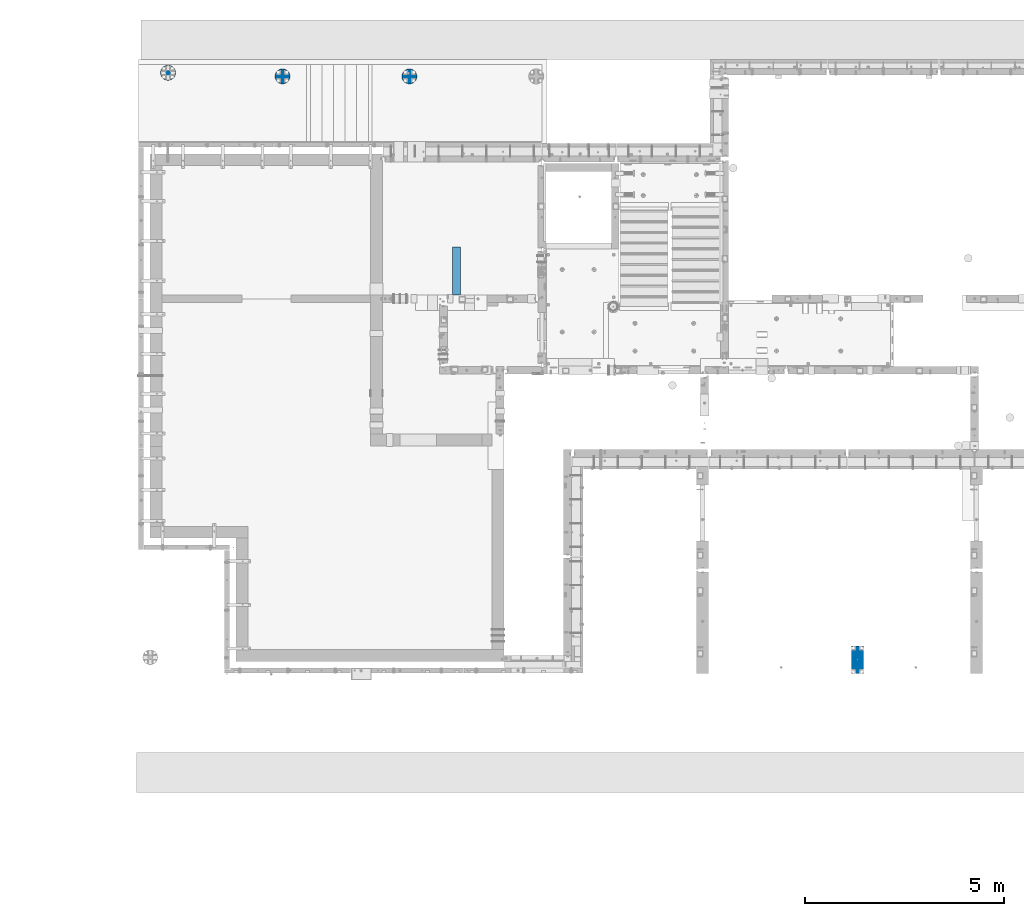
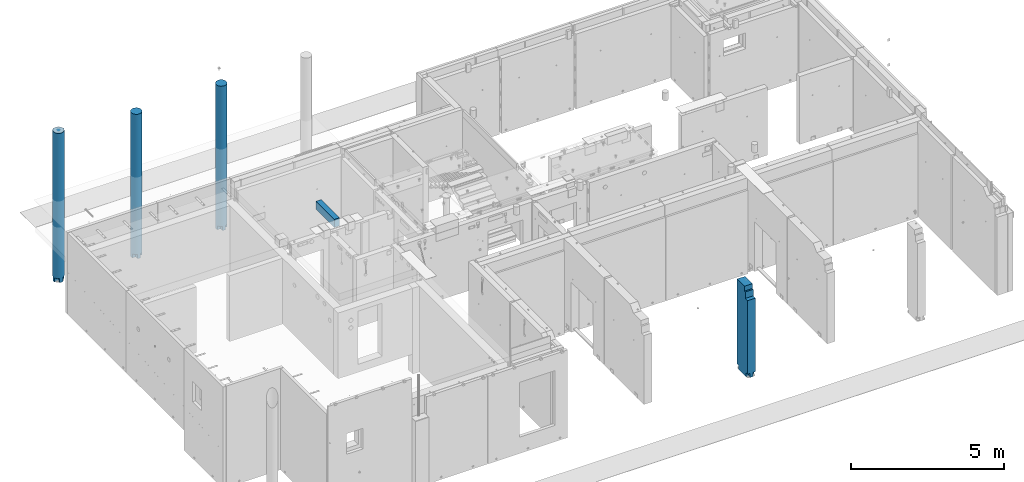
# One storey, part 3 of 264: 5 columns, 5 elements without a shape of their own.
"""IFC2X3 building model written with IfcOpenShell, lengths in millimetres."""

from ifc_helpers import new_model, si_unit, frame, origin_with_axes, place, context, subcontext, project, spatial, faceted_brep, material, type_object, element, aggregate, save


model = new_model("IFC2X3")

# Units and contexts
model_context = context("Model", 3, precision=1e-05, world=origin_with_axes())
body_context = subcontext(model_context, "Body", "Model", "MODEL_VIEW")
ifc_project = project(units=[si_unit("LENGTHUNIT", "METRE", prefix="MILLI"), si_unit("AREAUNIT", "SQUARE_METRE"), si_unit("VOLUMEUNIT", "CUBIC_METRE"), si_unit("MASSUNIT", "GRAM", prefix="KILO"), si_unit("TIMEUNIT", "SECOND"), si_unit("PLANEANGLEUNIT", "RADIAN"), si_unit("SOLIDANGLEUNIT", "STERADIAN"), si_unit("THERMODYNAMICTEMPERATUREUNIT", "DEGREE_CELSIUS"), si_unit("LUMINOUSINTENSITYUNIT", "LUMEN")], contexts=[model_context])

# Site, building, storey
site_placement = place(None, origin_with_axes())
site = spatial("IfcSite", under=ifc_project, at=site_placement, CompositionType="ELEMENT")
building_placement = place(site_placement, origin_with_axes())
building = spatial("IfcBuilding", under=site, at=building_placement, CompositionType="ELEMENT")
storey_placement = place(building_placement, origin_with_axes())
storey = spatial("IfcBuildingStorey", under=building, at=storey_placement, Name="K", CompositionType="ELEMENT", Elevation=0.0)

# Assembly, column
assembly_1_placement = place(storey_placement, origin_with_axes())
assembly_1 = element("IfcElementAssembly", 1, at=assembly_1_placement, inside=storey, AssemblyPlace="NOTDEFINED", PredefinedType="REINFORCEMENT_UNIT")
ifc_material_1 = material(Name="CONCRETE/C35/45")
column_type_1 = type_object("IfcColumnType", Name="D380", PredefinedType="NOTDEFINED")
column_1_placement = place(assembly_1_placement, frame((14374.9987952044, 22579.984888838, 78490.0), z_axis=(0.0, -1.0, 0.0), x_axis=(0.0, 0.0, 1.0)))
column_1 = element("IfcColumn", 2, at=column_1_placement, type_object=column_type_1, material=ifc_material_1, ObjectType="D380", context=body_context, shape_type="Brep", body=[
    faceted_brep([(0.000343322768458165, -58.9912653237152, 59.0010429997965), (165.000343322783, -58.9912653237152, 59.0010429997965), (165.000343322783, -58.9912653237152, 179.698598994491), (0.00034332278301008, -58.9912653237152, 179.698598994488), (165.000343322783, -179.695632968873, 59.0010429997965), (0.00034332278301008, -179.695632968873, 59.0010429997965), (165.000343322783, -175.537111177146, 72.7098521493681), (165.000343322783, -157.979226337484, 105.558344273726), (165.000343322783, -134.350288425445, 134.350288425445), (165.000343322783, -105.558344273726, 157.979226337484), (165.000343322783, -72.7098521493681, 175.537111177146), (0.00034332278301008, -179.699329936011, -58.9888557324375), (0.000343322768458165, -58.9912653237152, -58.9888557324375), (165.000343322783, -58.9912653237152, -58.9888557324375), (165.000343322783, -179.699329936011, -58.9888557324375), (165.000343322783, -58.9912653237152, -179.698598994488), (0.00034332278301008, -58.9912653237152, -179.698598994488), (0.00034332278301008, 58.9986334085152, -179.6963639104), (0.000343322768458165, 58.9986334085152, -58.9888557324375), (165.000343322783, 58.9986334085152, -58.9888557324375), (165.000343322783, 58.9986334085152, -179.696363910396), (0.00034332278301008, 179.699329936011, -58.9888557324375), (165.000343322783, 179.699329936011, -58.9888557324375), (0.00034332278301008, 0.0, 190.0), (0.00034332278301008, -37.0671611830658, 186.349203276615), (5750.0, -37.0671611830658, 186.349203276615), (5750.0, 0.0, 190.0), (0.00034332278301008, 37.0671611830658, 186.349203276615), (5750.0, 37.0671611830658, 186.349203276615), (5750.0, 157.979226337484, 105.558344273726), (5750.0, 175.537111177146, 72.7098521493681), (165.000343322783, 175.537111177146, 72.7098521493681), (165.000343322783, 157.979226337484, 105.558344273726), (5750.0, 134.350288425445, 134.350288425445), (165.000343322783, 134.350288425445, 134.350288425445), (5750.0, 105.558344273726, 157.979226337484), (165.000343322783, 105.558344273726, 157.979226337484), (5750.0, 72.7098521493681, 175.537111177146), (165.000343322783, 72.7098521493681, 175.537111177146), (165.000343322783, 58.9986334085152, 179.696363910396), (0.00034332278301008, 58.9986334085152, 179.6963639104), (0.000343322768458165, 58.9986334085152, 59.0010429997965), (165.000343322783, 58.9986334085152, 59.0010429997965), (165.000343322783, 179.695632968873, 59.0010429997965), (0.00034332278301008, 179.695632968873, 59.0010429997965), (5750.0, 186.349203276615, 37.0671611830658), (0.00034332278301008, 186.349203276615, 37.0671611830658), (0.00034332278301008, 190.0, 0.0), (5750.0, 190.0, 0.0), (0.00034332278301008, 186.349203276615, -37.0671611830658), (5750.0, 186.349203276615, -37.0671611830658), (5750.0, 175.537111177146, -72.7098521493681), (165.000343322783, 175.537111177146, -72.7098521493681), (5750.0, 157.979226337484, -105.558344273726), (165.000343322783, 157.979226337484, -105.558344273726), (5750.0, 134.350288425445, -134.350288425445), (165.000343322783, 134.350288425445, -134.350288425445), (5750.0, 105.558344273726, -157.979226337484), (165.000343322783, 105.558344273726, -157.979226337484), (5750.0, 72.7098521493681, -175.537111177146), (165.000343322783, 72.7098521493681, -175.537111177146), (5750.0, 37.0671611830658, -186.349203276615), (0.00034332278301008, 37.0671611830658, -186.349203276615), (0.00034332278301008, 0.0, -190.0), (5750.0, 0.0, -190.0), (0.00034332278301008, -37.0671611830658, -186.349203276615), (5750.0, -37.0671611830658, -186.349203276615), (5750.0, -72.7098521493681, -175.537111177146), (165.000343322783, -72.7098521493681, -175.537111177146), (5750.0, -105.558344273726, -157.979226337484), (165.000343322783, -105.558344273726, -157.979226337484), (5750.0, -134.350288425445, -134.350288425445), (165.000343322783, -134.350288425445, -134.350288425445), (5750.0, -157.979226337484, -105.558344273726), (165.000343322783, -157.979226337484, -105.558344273726), (5750.0, -175.537111177146, -72.7098521493681), (165.000343322783, -175.537111177146, -72.7098521493681), (5750.0, -186.349203276615, -37.0671611830658), (0.00034332278301008, -186.349203276615, -37.0671611830658), (0.00034332278301008, -190.0, 0.0), (5750.0, -190.0, 0.0), (5750.0, -72.7098521493681, 175.537111177146), (5750.0, -105.558344273726, 157.979226337484), (5750.0, -134.350288425445, 134.350288425445), (5750.0, -157.979226337484, 105.558344273726), (5750.0, -175.537111177146, 72.7098521493681), (5750.0, -186.349203276615, 37.0671611830658), (0.00034332278301008, -186.349203276615, 37.0671611830658)], [[[0, 1, 2, 3]], [[4, 1, 0, 5]], [[6, 7, 8, 9, 10, 2, 1, 4]], [[11, 12, 13, 14]], [[15, 13, 12, 16]], [[17, 18, 19, 20]], [[21, 22, 19, 18]], [[23, 24, 25, 26]], [[27, 23, 26, 28]], [[29, 30, 31, 32]], [[33, 29, 32, 34]], [[35, 33, 34, 36]], [[37, 35, 36, 38]], [[27, 28, 37, 38, 39, 40]], [[41, 42, 43, 44]], [[40, 39, 42, 41]], [[38, 36, 34, 32, 31, 43, 42, 39]], [[30, 45, 46, 44, 43, 31]], [[47, 46, 45, 48]], [[49, 47, 48, 50]], [[21, 49, 50, 51, 52, 22]], [[51, 53, 54, 52]], [[53, 55, 56, 54]], [[55, 57, 58, 56]], [[57, 59, 60, 58]], [[20, 19, 22, 52, 54, 56, 58, 60]], [[59, 61, 62, 17, 20, 60]], [[63, 62, 61, 64]], [[65, 63, 64, 66]], [[16, 65, 66, 67, 68, 15]], [[67, 69, 70, 68]], [[69, 71, 72, 70]], [[71, 73, 74, 72]], [[73, 75, 76, 74]], [[14, 13, 15, 68, 70, 72, 74, 76]], [[75, 77, 78, 11, 14, 76]], [[79, 78, 77, 80]], [[75, 73, 71, 69, 67, 66, 64, 61, 59, 57, 55, 53, 51, 50, 48, 45, 30, 29, 33, 35, 37, 28, 26, 25, 81, 82, 83, 84, 85, 86, 80, 77]], [[87, 79, 80, 86]], [[3, 24, 23, 27, 40, 41, 44, 46, 47, 49, 21, 18, 17, 62, 63, 65, 16, 12, 11, 78, 79, 87, 5, 0]], [[81, 25, 24, 3, 2, 10]], [[82, 81, 10, 9]], [[83, 82, 9, 8]], [[84, 83, 8, 7]], [[85, 84, 7, 6]], [[87, 86, 85, 6, 4, 5]]]),
])
aggregate(assembly_1, [column_1])

assembly_2_placement = place(storey_placement, origin_with_axes())
assembly_2 = element("IfcElementAssembly", 3, at=assembly_2_placement, inside=storey, AssemblyPlace="NOTDEFINED", PredefinedType="REINFORCEMENT_UNIT")
column_2_placement = place(assembly_2_placement, frame((11179.9987952044, 22579.984888838, 78490.0), z_axis=(0.0, -1.0, 0.0), x_axis=(0.0, 0.0, 1.0)))
column_2 = element("IfcColumn", 4, at=column_2_placement, type_object=column_type_1, material=ifc_material_1, ObjectType="D380", context=body_context, shape_type="Brep", body=[
    faceted_brep([(0.000343322768458165, -58.9912653237152, 59.0010429997965), (165.000343322783, -58.9912653237152, 59.0010429997965), (165.000343322783, -58.9912653237152, 179.698598994491), (0.00034332278301008, -58.9912653237152, 179.698598994488), (165.000343322783, -179.695632968873, 59.0010429997965), (0.00034332278301008, -179.695632968873, 59.0010429997965), (165.000343322783, -175.537111177146, 72.7098521493681), (165.000343322783, -157.979226337484, 105.558344273726), (165.000343322783, -134.350288425445, 134.350288425445), (165.000343322783, -105.558344273726, 157.979226337484), (165.000343322783, -72.7098521493681, 175.537111177146), (0.00034332278301008, -179.699329936011, -58.9888557324375), (0.000343322768458165, -58.9912653237152, -58.9888557324375), (165.000343322783, -58.9912653237152, -58.9888557324375), (165.000343322783, -179.699329936011, -58.9888557324375), (165.000343322783, -58.9912653237152, -179.698598994488), (0.00034332278301008, -58.9912653237152, -179.698598994488), (0.00034332278301008, 58.9986334085152, -179.6963639104), (0.000343322768458165, 58.9986334085152, -58.9888557324375), (165.000343322783, 58.9986334085152, -58.9888557324375), (165.000343322783, 58.9986334085152, -179.696363910396), (0.00034332278301008, 179.699329936011, -58.9888557324375), (165.000343322783, 179.699329936011, -58.9888557324375), (0.00034332278301008, 0.0, 190.0), (0.00034332278301008, -37.0671611830658, 186.349203276615), (5750.0, -37.0671611830658, 186.349203276615), (5750.0, 0.0, 190.0), (0.00034332278301008, 37.0671611830658, 186.349203276615), (5750.0, 37.0671611830658, 186.349203276615), (5750.0, 157.979226337484, 105.558344273726), (5750.0, 175.537111177146, 72.7098521493681), (165.000343322783, 175.537111177146, 72.7098521493681), (165.000343322783, 157.979226337484, 105.558344273726), (5750.0, 134.350288425445, 134.350288425445), (165.000343322783, 134.350288425445, 134.350288425445), (5750.0, 105.558344273726, 157.979226337484), (165.000343322783, 105.558344273726, 157.979226337484), (5750.0, 72.7098521493681, 175.537111177146), (165.000343322783, 72.7098521493681, 175.537111177146), (165.000343322783, 58.9986334085152, 179.696363910396), (0.00034332278301008, 58.9986334085152, 179.6963639104), (0.000343322768458165, 58.9986334085152, 59.0010429997965), (165.000343322783, 58.9986334085152, 59.0010429997965), (165.000343322783, 179.695632968873, 59.0010429997965), (0.00034332278301008, 179.695632968873, 59.0010429997965), (5750.0, 186.349203276615, 37.0671611830658), (0.00034332278301008, 186.349203276615, 37.0671611830658), (0.00034332278301008, 190.0, 0.0), (5750.0, 190.0, 0.0), (0.00034332278301008, 186.349203276615, -37.0671611830658), (5750.0, 186.349203276615, -37.0671611830658), (5750.0, 175.537111177146, -72.7098521493681), (165.000343322783, 175.537111177146, -72.7098521493681), (5750.0, 157.979226337484, -105.558344273726), (165.000343322783, 157.979226337484, -105.558344273726), (5750.0, 134.350288425445, -134.350288425445), (165.000343322783, 134.350288425445, -134.350288425445), (5750.0, 105.558344273726, -157.979226337484), (165.000343322783, 105.558344273726, -157.979226337484), (5750.0, 72.7098521493681, -175.537111177146), (165.000343322783, 72.7098521493681, -175.537111177146), (5750.0, 37.0671611830658, -186.349203276615), (0.00034332278301008, 37.0671611830658, -186.349203276615), (0.00034332278301008, 0.0, -190.0), (5750.0, 0.0, -190.0), (0.00034332278301008, -37.0671611830658, -186.349203276615), (5750.0, -37.0671611830658, -186.349203276615), (5750.0, -72.7098521493681, -175.537111177146), (165.000343322783, -72.7098521493681, -175.537111177146), (5750.0, -105.558344273726, -157.979226337484), (165.000343322783, -105.558344273726, -157.979226337484), (5750.0, -134.350288425445, -134.350288425445), (165.000343322783, -134.350288425445, -134.350288425445), (5750.0, -157.979226337484, -105.558344273726), (165.000343322783, -157.979226337484, -105.558344273726), (5750.0, -175.537111177146, -72.7098521493681), (165.000343322783, -175.537111177146, -72.7098521493681), (5750.0, -186.349203276615, -37.0671611830658), (0.00034332278301008, -186.349203276615, -37.0671611830658), (0.00034332278301008, -190.0, 0.0), (5750.0, -190.0, 0.0), (5750.0, -72.7098521493681, 175.537111177146), (5750.0, -105.558344273726, 157.979226337484), (5750.0, -134.350288425445, 134.350288425445), (5750.0, -157.979226337484, 105.558344273726), (5750.0, -175.537111177146, 72.7098521493681), (5750.0, -186.349203276615, 37.0671611830658), (0.00034332278301008, -186.349203276615, 37.0671611830658)], [[[0, 1, 2, 3]], [[4, 1, 0, 5]], [[6, 7, 8, 9, 10, 2, 1, 4]], [[11, 12, 13, 14]], [[15, 13, 12, 16]], [[17, 18, 19, 20]], [[21, 22, 19, 18]], [[23, 24, 25, 26]], [[27, 23, 26, 28]], [[29, 30, 31, 32]], [[33, 29, 32, 34]], [[35, 33, 34, 36]], [[37, 35, 36, 38]], [[27, 28, 37, 38, 39, 40]], [[41, 42, 43, 44]], [[40, 39, 42, 41]], [[38, 36, 34, 32, 31, 43, 42, 39]], [[30, 45, 46, 44, 43, 31]], [[47, 46, 45, 48]], [[49, 47, 48, 50]], [[21, 49, 50, 51, 52, 22]], [[51, 53, 54, 52]], [[53, 55, 56, 54]], [[55, 57, 58, 56]], [[57, 59, 60, 58]], [[20, 19, 22, 52, 54, 56, 58, 60]], [[59, 61, 62, 17, 20, 60]], [[63, 62, 61, 64]], [[65, 63, 64, 66]], [[16, 65, 66, 67, 68, 15]], [[67, 69, 70, 68]], [[69, 71, 72, 70]], [[71, 73, 74, 72]], [[73, 75, 76, 74]], [[14, 13, 15, 68, 70, 72, 74, 76]], [[75, 77, 78, 11, 14, 76]], [[79, 78, 77, 80]], [[75, 73, 71, 69, 67, 66, 64, 61, 59, 57, 55, 53, 51, 50, 48, 45, 30, 29, 33, 35, 37, 28, 26, 25, 81, 82, 83, 84, 85, 86, 80, 77]], [[87, 79, 80, 86]], [[3, 24, 23, 27, 40, 41, 44, 46, 47, 49, 21, 18, 17, 62, 63, 65, 16, 12, 11, 78, 79, 87, 5, 0]], [[81, 25, 24, 3, 2, 10]], [[82, 81, 10, 9]], [[83, 82, 9, 8]], [[84, 83, 8, 7]], [[85, 84, 7, 6]], [[87, 86, 85, 6, 4, 5]]]),
])
aggregate(assembly_2, [column_2])

assembly_3_placement = place(storey_placement, origin_with_axes())
assembly_3 = element("IfcElementAssembly", 5, at=assembly_3_placement, inside=storey, AssemblyPlace="NOTDEFINED", PredefinedType="REINFORCEMENT_UNIT")
column_3_placement = place(assembly_3_placement, frame((8299.99879520436, 22669.984888838, 78490.0), z_axis=(0.0, -1.0, 0.0), x_axis=(0.0, 0.0, 1.0)))
column_3 = element("IfcColumn", 6, at=column_3_placement, type_object=column_type_1, material=ifc_material_1, ObjectType="D380", context=body_context, shape_type="Brep", body=[
    faceted_brep([(0.000343322768458165, -58.9912653237152, 59.0010429997965), (165.000343322783, -58.9912653237152, 59.0010429997965), (165.000343322783, -58.9912653237152, 179.698598994491), (0.00034332278301008, -58.9912653237152, 179.698598994488), (165.000343322783, -179.695632968873, 59.0010429997965), (0.00034332278301008, -179.695632968873, 59.0010429997965), (165.000343322783, -175.537111177146, 72.7098521493681), (165.000343322783, -157.979226337484, 105.558344273726), (165.000343322783, -134.350288425445, 134.350288425445), (165.000343322783, -105.558344273726, 157.979226337484), (165.000343322783, -72.7098521493681, 175.537111177146), (0.00034332278301008, -179.699329936011, -58.9888557324375), (0.000343322768458165, -58.9912653237152, -58.9888557324375), (165.000343322783, -58.9912653237152, -58.9888557324375), (165.000343322783, -179.699329936011, -58.9888557324375), (165.000343322783, -58.9912653237152, -179.698598994488), (0.00034332278301008, -58.9912653237152, -179.698598994488), (0.00034332278301008, 58.9986334085152, -179.6963639104), (0.000343322768458165, 58.9986334085152, -58.9888557324375), (165.000343322783, 58.9986334085152, -58.9888557324375), (165.000343322783, 58.9986334085152, -179.696363910396), (0.00034332278301008, 179.699329936011, -58.9888557324375), (165.000343322783, 179.699329936011, -58.9888557324375), (0.00034332278301008, 0.0, 190.0), (0.00034332278301008, -37.0671611830658, 186.349203276615), (5945.0, -37.0671611830639, 186.349203276615), (5945.0, 0.0, 190.0), (0.00034332278301008, 37.0671611830658, 186.349203276615), (5945.0, 37.0671611830639, 186.349203276615), (5945.0, 157.979226337484, 105.558344273726), (5945.0, 175.537111177145, 72.7098521493681), (165.000343322783, 175.537111177146, 72.7098521493681), (165.000343322783, 157.979226337484, 105.558344273726), (5945.0, 134.350288425444, 134.350288425445), (165.000343322783, 134.350288425445, 134.350288425445), (5945.0, 105.558344273724, 157.979226337484), (165.000343322783, 105.558344273726, 157.979226337484), (5945.0, 72.7098521493663, 175.537111177146), (165.000343322783, 72.7098521493681, 175.537111177146), (165.000343322783, 58.9986334085152, 179.696363910396), (0.00034332278301008, 58.9986334085152, 179.6963639104), (0.000343322768458165, 58.9986334085152, 59.0010429997965), (165.000343322783, 58.9986334085152, 59.0010429997965), (165.000343322783, 179.695632968873, 59.0010429997965), (0.00034332278301008, 179.695632968873, 59.0010429997965), (5945.0, 186.349203276613, 37.0671611830658), (0.00034332278301008, 186.349203276615, 37.0671611830658), (0.00034332278301008, 190.0, 0.0), (5945.0, 190.0, 0.0), (0.00034332278301008, 186.349203276615, -37.0671611830658), (5945.0, 186.349203276613, -37.0671611830658), (5945.0, 175.537111177145, -72.7098521493681), (165.000343322783, 175.537111177146, -72.7098521493681), (5945.0, 157.979226337484, -105.558344273726), (165.000343322783, 157.979226337484, -105.558344273726), (5945.0, 134.350288425444, -134.350288425445), (165.000343322783, 134.350288425445, -134.350288425445), (5945.0, 105.558344273724, -157.979226337484), (165.000343322783, 105.558344273726, -157.979226337484), (5945.0, 72.7098521493663, -175.537111177146), (165.000343322783, 72.7098521493681, -175.537111177146), (5945.0, 37.0671611830639, -186.349203276615), (0.00034332278301008, 37.0671611830658, -186.349203276615), (0.00034332278301008, 0.0, -190.0), (5945.0, 0.0, -190.0), (0.00034332278301008, -37.0671611830658, -186.349203276615), (5945.0, -37.0671611830639, -186.349203276615), (5945.0, -72.7098521493663, -175.537111177146), (165.000343322783, -72.7098521493681, -175.537111177146), (5945.0, -105.558344273724, -157.979226337484), (165.000343322783, -105.558344273726, -157.979226337484), (5945.0, -134.350288425445, -134.350288425445), (165.000343322783, -134.350288425445, -134.350288425445), (5945.0, -157.979226337484, -105.558344273726), (165.000343322783, -157.979226337484, -105.558344273726), (5945.0, -175.537111177144, -72.7098521493681), (165.000343322783, -175.537111177146, -72.7098521493681), (5945.0, -186.349203276613, -37.0671611830658), (0.00034332278301008, -186.349203276615, -37.0671611830658), (0.00034332278301008, -190.0, 0.0), (5945.0, -190.0, 0.0), (5945.0, -72.7098521493663, 175.537111177146), (5945.0, -105.558344273724, 157.979226337484), (5945.0, -134.350288425445, 134.350288425445), (5945.0, -157.979226337484, 105.558344273726), (5945.0, -175.537111177144, 72.7098521493681), (5945.0, -186.349203276613, 37.0671611830658), (0.00034332278301008, -186.349203276615, 37.0671611830658)], [[[0, 1, 2, 3]], [[4, 1, 0, 5]], [[6, 7, 8, 9, 10, 2, 1, 4]], [[11, 12, 13, 14]], [[15, 13, 12, 16]], [[17, 18, 19, 20]], [[21, 22, 19, 18]], [[23, 24, 25, 26]], [[27, 23, 26, 28]], [[29, 30, 31, 32]], [[33, 29, 32, 34]], [[35, 33, 34, 36]], [[37, 35, 36, 38]], [[27, 28, 37, 38, 39, 40]], [[41, 42, 43, 44]], [[40, 39, 42, 41]], [[38, 36, 34, 32, 31, 43, 42, 39]], [[30, 45, 46, 44, 43, 31]], [[47, 46, 45, 48]], [[49, 47, 48, 50]], [[21, 49, 50, 51, 52, 22]], [[51, 53, 54, 52]], [[53, 55, 56, 54]], [[55, 57, 58, 56]], [[57, 59, 60, 58]], [[20, 19, 22, 52, 54, 56, 58, 60]], [[59, 61, 62, 17, 20, 60]], [[63, 62, 61, 64]], [[65, 63, 64, 66]], [[16, 65, 66, 67, 68, 15]], [[67, 69, 70, 68]], [[69, 71, 72, 70]], [[71, 73, 74, 72]], [[73, 75, 76, 74]], [[14, 13, 15, 68, 70, 72, 74, 76]], [[75, 77, 78, 11, 14, 76]], [[79, 78, 77, 80]], [[75, 73, 71, 69, 67, 66, 64, 61, 59, 57, 55, 53, 51, 50, 48, 45, 30, 29, 33, 35, 37, 28, 26, 25, 81, 82, 83, 84, 85, 86, 80, 77]], [[87, 79, 80, 86]], [[3, 24, 23, 27, 40, 41, 44, 46, 47, 49, 21, 18, 17, 62, 63, 65, 16, 12, 11, 78, 79, 87, 5, 0]], [[81, 25, 24, 3, 2, 10]], [[82, 81, 10, 9]], [[83, 82, 9, 8]], [[84, 83, 8, 7]], [[85, 84, 7, 6]], [[87, 86, 85, 6, 4, 5]]]),
])
aggregate(assembly_3, [column_3])

assembly_4_placement = place(storey_placement, origin_with_axes())
assembly_4 = element("IfcElementAssembly", 7, at=assembly_4_placement, inside=storey, AssemblyPlace="NOTDEFINED", PredefinedType="REINFORCEMENT_UNIT")
ifc_material_2 = material(Name="CONCRETE/C30/37")
column_type_2 = type_object("IfcColumnType", PredefinedType="NOTDEFINED")
column_4_placement = place(assembly_4_placement, frame((25660.0001684954, 7887.49670859649, 77700.0), z_axis=(0.0, 1.0, 0.0), x_axis=(0.0, 0.0, 1.0)))
column_4 = element("IfcColumn", 8, at=column_4_placement, type_object=column_type_2, material=ifc_material_2, context=body_context, shape_type="Brep", body=[
    faceted_brep([(0.00034332278301008, -150.0, 252.5), (165.000343322783, -150.0, 252.5), (165.000343322783, -60.0, 252.5), (0.000343322768458165, -60.0, 252.5), (165.000343322783, -60.0, 342.500000000002), (165.000343322783, -150.0, 342.5), (0.00034332278301008, -60.0, 342.5), (0.00034332278301008, 150.0, 252.5), (0.00034332278301008, 60.0, 252.5), (165.000343322783, 60.0, 252.5), (165.000343322783, 149.999991736422, 252.5), (165.000343322783, 60.0, 342.5), (0.00034332278301008, 60.0, 342.5), (165.000343322783, 150.0, 342.5), (165.000343322783, 150.0, -342.5), (165.000343322783, 60.0, -342.5), (165.000343322783, 60.0, -252.5), (165.000343322783, 149.999979571519, -252.5), (0.00034332278301008, 60.0, -252.5), (0.00034332278301008, 60.0, -342.5), (0.00034332278301008, 150.0, -252.5), (3540.0, 150.0, 342.5), (3540.0, 149.999831504603, -137.496708596485), (3350.0, 149.999831504603, -137.496708596485), (3350.0, 149.999831504603, -197.496708596485), (3090.0, 149.999925954333, -197.496704101563), (3090.0, 150.0, -342.5), (165.000343322783, -150.0, -342.5), (165.000343322783, -149.999999999993, -252.5), (165.000343322783, -60.0, -252.5), (165.000343322783, -60.0, -342.499999999999), (0.000343322768458165, -60.0, -252.5), (0.00034332278301008, -150.0, -252.5), (0.00034332278301008, -60.0, -342.5), (3090.0, -150.0, -342.5), (3090.0, -149.999999999996, -197.496704101563), (3350.0, -150.0, -197.496708596485), (3350.0, -150.0, -137.496708596485), (3540.0, -150.0, -137.496708596485), (3540.0, -150.0, 342.5)], [[[0, 1, 2, 3]], [[4, 2, 1, 5]], [[6, 3, 2, 4]], [[7, 8, 9, 10]], [[11, 9, 8, 12]], [[13, 10, 9, 11]], [[14, 15, 16, 17]], [[18, 16, 15, 19]], [[17, 16, 18, 20]], [[7, 10, 13, 21, 22, 23, 24, 25, 26, 14, 17, 20]], [[27, 28, 29, 30]], [[31, 29, 28, 32]], [[33, 30, 29, 31]], [[19, 15, 14, 26, 34, 27, 30, 33]], [[25, 35, 34, 26]], [[24, 36, 35, 25]], [[23, 37, 36, 24]], [[22, 38, 37, 23]], [[21, 39, 38, 22]], [[0, 32, 28, 27, 34, 35, 36, 37, 38, 39, 5, 1]], [[12, 8, 7, 20, 18, 19, 33, 31, 32, 0, 3, 6]], [[39, 21, 13, 11, 12, 6, 4, 5]]]),
])
aggregate(assembly_4, [column_4])

assembly_5_placement = place(storey_placement, origin_with_axes())
assembly_5 = element("IfcElementAssembly", 9, at=assembly_5_placement, inside=storey, Name="Steel Assembly", AssemblyPlace="NOTDEFINED", PredefinedType="NOTDEFINED")
ifc_material_3 = material()
column_type_3 = type_object("IfcColumnType", PredefinedType="NOTDEFINED")
column_5_placement = place(assembly_5_placement, frame((15559.999845922, 17679.9995407462, 81440.0), z_axis=(0.0, 1.0, 0.0), x_axis=(0.0, 0.0, 1.0)))
column_5 = element("IfcColumn", 10, at=column_5_placement, type_object=column_type_3, material=ifc_material_3, context=body_context, shape_type="Brep", body=[
    faceted_brep([(0.0, 100.0, -600.0), (0.0, 100.0, 600.0), (320.0, 100.0, 600.0), (320.0, 100.0, -600.0), (0.0, -100.0, 600.0), (320.0, -100.0, 600.0), (0.0, -100.0, -600.0), (320.0, -100.0, -600.0)], [[[0, 1, 2, 3]], [[1, 4, 5, 2]], [[4, 6, 7, 5]], [[6, 0, 3, 7]], [[5, 7, 3, 2]], [[6, 4, 1, 0]]]),
])
aggregate(assembly_5, [column_5])

save(model, "model.ifc")
